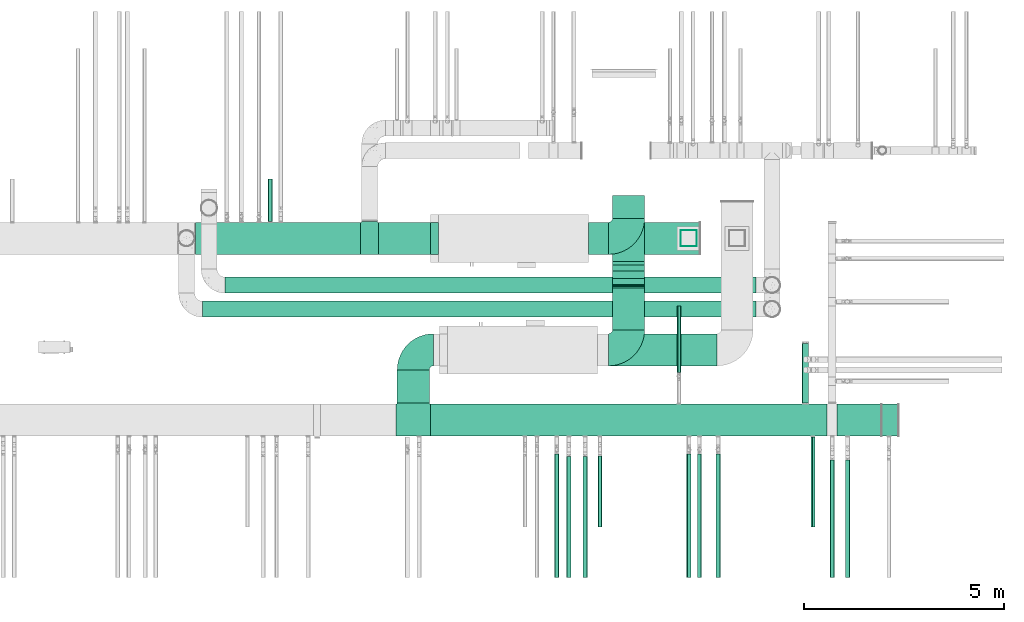
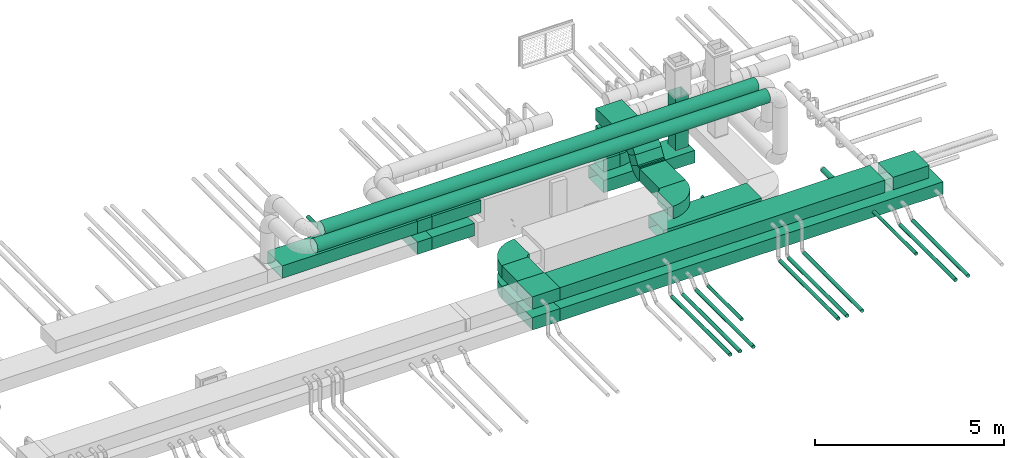
# One storey, part 3 of 91: 31 flow segments, 10 flow fittings.
"""IFC2X3 building model written with IfcOpenShell, lengths in millimetres."""

import ifcopenshell
import ifcopenshell.guid

model = None  # the IFC model being written
_history = None  # IfcOwnerHistory: only IFC2X3 demands one
_inside = {}  # id of a spatial element -> (the spatial element, [elements in it])
_under = {}  # id of a project, library or spatial element -> (it, [spatial elements below it])
_declared = {}  # id of a project -> (the project, [libraries it declares])
_typed = {}  # id of a type object -> (the type object, [elements of that type])
_made_of = {}  # id of a material, layer set ... -> (it, [elements and type objects made of it])


def new_model(schema):
    """Start an empty IFC model of exactly this schema.

    Asked for "IFC4X3", IfcOpenShell would pick the latest addendum, in which some entities
    have other attributes; the version numbers below select the first issue.
    IFC2X3 requires an IfcOwnerHistory on every rooted entity: one is made here for all.
    """
    global model, _history
    if schema == "IFC4X3":
        model = ifcopenshell.file(schema_version=(4, 3, 0, 0))
    else:
        model = ifcopenshell.file(schema=schema)
    _inside.clear()
    _under.clear()
    _declared.clear()
    _typed.clear()
    _made_of.clear()
    _history = None
    if model.schema == "IFC2X3":
        org = make("IfcOrganization", Name="unknown")
        user = make(
            "IfcPersonAndOrganization",
            ThePerson=make("IfcPerson", FamilyName="unknown"),
            TheOrganization=org,
        )
        app = make(
            "IfcApplication",
            ApplicationDeveloper=org,
            Version="unknown",
            ApplicationFullName="unknown",
            ApplicationIdentifier="unknown",
        )
        _history = make(
            "IfcOwnerHistory",
            OwningUser=user,
            OwningApplication=app,
            ChangeAction="ADDED",
            CreationDate=0,
        )
    return model


def make(cls, **values):
    """One entity of the class cls with the attributes given. An attribute that is None is left unset."""
    return model.create_entity(
        cls, **{name: value for name, value in values.items() if value is not None}
    )


def entity(cls, *values):
    """Any entity or typed value of the class cls, its attributes in the order of the schema. None: left unset."""
    e = model.create_entity(cls)
    for i, value in enumerate(values):
        if value is not None:
            e[i] = value
    return e


def rooted(cls, **values):
    """An entity with a GlobalId (a new one), such as an element, a storey or a relation."""
    return make(cls, GlobalId=ifcopenshell.guid.new(), OwnerHistory=_history, **values)


def si_unit(unit_type, name, prefix=None):
    """IfcSIUnit, for example si_unit("LENGTHUNIT", "METRE", prefix="MILLI")."""
    return make("IfcSIUnit", UnitType=unit_type, Prefix=prefix, Name=name)


def converted_unit(unit_type, name, factor, base, dimensions=None, offset=None):
    """IfcConversionBasedUnit, such as the inch: factor (a typed value) times the base unit."""
    return make(
        "IfcConversionBasedUnit"
        if offset is None
        else "IfcConversionBasedUnitWithOffset",
        ConversionOffset=offset,
        Dimensions=None
        if dimensions is None
        else entity("IfcDimensionalExponents", *dimensions),
        UnitType=unit_type,
        Name=name,
        ConversionFactor=make(
            "IfcMeasureWithUnit", ValueComponent=factor, UnitComponent=base
        ),
    )


def derived_unit(unit_type, elements):
    """IfcDerivedUnit: a product of units, each with its exponent."""
    return make(
        "IfcDerivedUnit",
        Elements=[
            make("IfcDerivedUnitElement", Unit=unit, Exponent=power)
            for unit, power in elements
        ],
        UnitType=unit_type,
    )


def assignment(units):
    """IfcUnitAssignment: the units of a project."""
    return None if units is None else make("IfcUnitAssignment", Units=units)


def point(xyz):
    """IfcCartesianPoint."""
    return None if xyz is None else make("IfcCartesianPoint", Coordinates=xyz)


def direction(xyz):
    """IfcDirection."""
    return None if xyz is None else make("IfcDirection", DirectionRatios=xyz)


def frame(location, z_axis=None, x_axis=None):
    """IfcAxis2Placement3D, a coordinate frame: its origin and axes. An axis left out is left unset."""
    return make(
        "IfcAxis2Placement3D",
        Location=point(location),
        Axis=direction(z_axis),
        RefDirection=direction(x_axis),
    )


def frame_2d(location, x_axis=None):
    """IfcAxis2Placement2D, a coordinate frame in the plane: its origin and x axis."""
    return make(
        "IfcAxis2Placement2D", Location=point(location), RefDirection=direction(x_axis)
    )


def origin_with_axes():
    """The frame at (0, 0, 0) with the z axis (0, 0, 1) and the x axis (1, 0, 0) written out."""
    return frame((0.0, 0.0, 0.0), z_axis=(0.0, 0.0, 1.0), x_axis=(1.0, 0.0, 0.0))


def origin_2d_with_axis():
    """The frame at (0, 0) in the plane with the x axis (1, 0) written out."""
    return frame_2d((0.0, 0.0), x_axis=(1.0, 0.0))


def place(relative_to, where):
    """IfcLocalPlacement: puts the frame where relative to a parent placement (None: the world)."""
    return make(
        "IfcLocalPlacement", PlacementRelTo=relative_to, RelativePlacement=where
    )


def context(
    kind, dimensions, precision=None, world=None, true_north=None, identifier=None
):
    """IfcGeometricRepresentationContext, for example the 3D "Model" context."""
    return make(
        "IfcGeometricRepresentationContext",
        ContextIdentifier=identifier,
        ContextType=kind,
        CoordinateSpaceDimension=dimensions,
        Precision=precision,
        WorldCoordinateSystem=world,
        TrueNorth=true_north,
    )


def subcontext(parent, identifier, kind, view, scale=None):
    """IfcGeometricRepresentationSubContext, for example "Body" below "Model"."""
    return make(
        "IfcGeometricRepresentationSubContext",
        ContextIdentifier=identifier,
        ContextType=kind,
        ParentContext=parent,
        TargetScale=scale,
        TargetView=view,
    )


def project(units=None, contexts=None):
    """IfcProject with its units and contexts."""
    return rooted(
        "IfcProject",
        Name="project",
        RepresentationContexts=contexts,
        UnitsInContext=assignment(units),
    )


def spatial(cls, under=None, at=None, **own):
    """A site, building, storey or space (cls), placed at a placement, below another one or the project."""
    s = rooted(cls, ObjectPlacement=at, **own)
    if under is not None:
        _under.setdefault(under.id(), (under, []))[1].append(s)
    return s


def profile(cls, at=None, kind="AREA", **sizes):
    """A parametric profile (cls). Its sizes go by their IFC names, for example OverallWidth=200.0."""
    return make(cls, ProfileType=kind, Position=at, **sizes)


def hollow_rectangle(**sizes):
    """IfcRectangleHollowProfileDef."""
    return profile("IfcRectangleHollowProfileDef", **sizes)


def hollow_circle(**sizes):
    """IfcCircleHollowProfileDef."""
    return profile("IfcCircleHollowProfileDef", **sizes)


def extrude(swept, where, along, depth):
    """IfcExtrudedAreaSolid: the profile swept, set in the frame where, extruded along a direction by depth."""
    return make(
        "IfcExtrudedAreaSolid",
        SweptArea=swept,
        Position=where,
        ExtrudedDirection=direction(along),
        Depth=depth,
    )


def faces_of(points, faces, orient=None, outer=None):
    """IfcFace entities. A face is a list of loops; a loop is a list of indices into points, from 0.

    orient and outer hold one flag for each loop. By default every Orientation is true, the
    first loop of a face is its IfcFaceOuterBound and the others are IfcFaceBound.
    """
    made = []
    for i, loops in enumerate(faces):
        bounds = []
        for j, loop in enumerate(loops):
            is_outer = j == 0 if outer is None else outer[i][j]
            bounds.append(
                make(
                    "IfcFaceOuterBound" if is_outer else "IfcFaceBound",
                    Bound=make("IfcPolyLoop", Polygon=[points[k] for k in loop]),
                    Orientation=True if orient is None else orient[i][j],
                )
            )
        made.append(make("IfcFace", Bounds=bounds))
    return made


def open_shell(faces, orient=None, outer=None):
    """The faces of one IfcOpenShell. surface_model builds it on its shared points."""
    return ("IfcOpenShell", faces, orient, outer)


def surface_model(cls, points, shells):
    """IfcFaceBasedSurfaceModel or IfcShellBasedSurfaceModel (cls): surfaces that need not close."""
    shared = [point(p) for p in points]
    made = [make(c, CfsFaces=faces_of(shared, fs, o, b)) for c, fs, o, b in shells]
    if cls == "IfcFaceBasedSurfaceModel":
        return make(cls, FbsmFaces=made)
    return make(cls, SbsmBoundary=made)


def shape(context_of_items, identifier, shape_type, items):
    """IfcShapeRepresentation: the items that make up one representation, for example the "Body"."""
    return make(
        "IfcShapeRepresentation",
        ContextOfItems=context_of_items,
        RepresentationIdentifier=identifier,
        RepresentationType=shape_type,
        Items=items,
    )


def source(mapping_origin, context_of_items, identifier, shape_type, items):
    """IfcRepresentationMap: a shape defined once, which mapped items show again and again."""
    return make(
        "IfcRepresentationMap",
        MappingOrigin=mapping_origin,
        MappedRepresentation=shape(context_of_items, identifier, shape_type, items),
    )


def transform(
    local_origin,
    x_axis=None,
    y_axis=None,
    z_axis=None,
    scale=None,
    scale2=None,
    scale3=None,
    uniform=True,
):
    """IfcCartesianTransformationOperator3D, or its non-uniform kind. x_axis, y_axis, z_axis: its Axis1, 2, 3."""
    if uniform:
        return make(
            "IfcCartesianTransformationOperator3D",
            Axis1=direction(x_axis),
            Axis2=direction(y_axis),
            LocalOrigin=point(local_origin),
            Scale=scale,
            Axis3=direction(z_axis),
        )
    return make(
        "IfcCartesianTransformationOperator3DnonUniform",
        Axis1=direction(x_axis),
        Axis2=direction(y_axis),
        LocalOrigin=point(local_origin),
        Scale=scale,
        Axis3=direction(z_axis),
        Scale2=scale2,
        Scale3=scale3,
    )


def mapped(mapping_source, mapping_target):
    """IfcMappedItem: shows the shape of a source again, moved by a transform."""
    return make(
        "IfcMappedItem", MappingSource=mapping_source, MappingTarget=mapping_target
    )


def material(Name=None, Category=None):
    """IfcMaterial."""
    return make("IfcMaterial", Name=Name, Category=Category)


def layer(
    of_material, thickness, ventilated=None, Name=None, Category=None, Priority=None
):
    """IfcMaterialLayer: one layer of a wall or slab, of a material (None: an air gap)."""
    return make(
        "IfcMaterialLayer",
        Material=of_material,
        LayerThickness=thickness,
        IsVentilated=ventilated,
        Name=Name,
        Category=Category,
        Priority=Priority,
    )


def layer_set(layers, Name=None):
    """IfcMaterialLayerSet."""
    return make("IfcMaterialLayerSet", MaterialLayers=layers, LayerSetName=Name)


def layer_usage(for_layer_set, set_direction, sense, offset, extent=None):
    """IfcMaterialLayerSetUsage: how a layer set lies in its element."""
    return make(
        "IfcMaterialLayerSetUsage",
        ForLayerSet=for_layer_set,
        LayerSetDirection=set_direction,
        DirectionSense=sense,
        OffsetFromReferenceLine=offset,
        ReferenceExtent=extent,
    )


def made_of(thing, what):
    """Note that an element or type object is made of a material, layer set ...; save() writes the relation."""
    if what is not None:
        _made_of.setdefault(what.id(), (what, []))[1].append(thing)
    return thing


def type_object(cls, material=None, **own):
    """A type object (cls), such as IfcWallType, which elements share."""
    return made_of(rooted(cls, **own), material)


def element(
    cls,
    number,
    at=None,
    inside=None,
    cuts=None,
    type_object=None,
    material=None,
    context=None,
    identifier="Body",
    shape_type=None,
    held_by="IfcProductDefinitionShape",
    body=None,
    shapes=None,
    **own,
):
    """One element of the class cls, such as IfcWall. Its Tag is "e" and its number.

    at: its placement. inside: the storey or other place that contains it. cuts: it is an
    opening in that element (IfcRelVoidsElement). A single representation is given by context,
    identifier, shape_type and body (its items); several are given by shapes. held_by: the class
    of the entity that holds the representations. save() writes the other relations.
    """
    e = rooted(cls, Tag="e%d" % number, ObjectPlacement=at, **own)
    if body is not None:
        shapes = [shape(context, identifier, shape_type, body)]
    if shapes is not None:
        e.Representation = make(held_by, Representations=shapes)
    if inside is not None:
        _inside.setdefault(inside.id(), (inside, []))[1].append(e)
    if cuts is not None:
        rooted(
            "IfcRelVoidsElement", RelatingBuildingElement=cuts, RelatedOpeningElement=e
        )
    if type_object is not None:
        _typed.setdefault(type_object.id(), (type_object, []))[1].append(e)
    return made_of(e, material)


def aggregate(whole, parts):
    """IfcRelAggregates: a whole, such as a stair, and the parts it consists of."""
    return rooted("IfcRelAggregates", RelatingObject=whole, RelatedObjects=parts)


def save(model, path):
    """Write the relations noted so far, then the file.

    IfcRelAggregates (storeys below a building ...), IfcRelContainedInSpatialStructure (elements
    in a storey), IfcRelDefinesByType, IfcRelAssociatesMaterial and IfcRelDeclares: one each for
    every whole, place, type object, material and project.
    """
    for whole, parts in _under.values():
        aggregate(whole, parts)
    for where, things in _inside.values():
        rooted(
            "IfcRelContainedInSpatialStructure",
            RelatedElements=things,
            RelatingStructure=where,
        )
    for kind, things in _typed.values():
        rooted("IfcRelDefinesByType", RelatedObjects=things, RelatingType=kind)
    for what, things in _made_of.values():
        rooted("IfcRelAssociatesMaterial", RelatedObjects=things, RelatingMaterial=what)
    for by, libraries in _declared.values():
        rooted("IfcRelDeclares", RelatingContext=by, RelatedDefinitions=libraries)
    model.write(path)


model = new_model("IFC2X3")

# Units and contexts
model_context = context("Model", 3, precision=1e-05, world=origin_with_axes(), true_north=direction((0.0, 1.0)))
body_context = subcontext(model_context, "Body", "Model", "MODEL_VIEW")
ifc_project = project(units=[si_unit("AREAUNIT", "SQUARE_METRE"), si_unit("VOLUMEUNIT", "CUBIC_METRE", prefix="DECI"), si_unit("TIMEUNIT", "SECOND"), si_unit("THERMODYNAMICTEMPERATUREUNIT", "DEGREE_CELSIUS"), si_unit("PRESSUREUNIT", "PASCAL"), si_unit("MASSUNIT", "GRAM", prefix="KILO"), si_unit("LENGTHUNIT", "METRE", prefix="MILLI"), si_unit("POWERUNIT", "WATT"), si_unit("ELECTRICCURRENTUNIT", "AMPERE"), si_unit("ELECTRICVOLTAGEUNIT", "VOLT"), derived_unit("VOLUMETRICFLOWRATEUNIT", [(si_unit("VOLUMEUNIT", "CUBIC_METRE", prefix="DECI"), 1), (si_unit("TIMEUNIT", "SECOND"), -1)]), derived_unit("LINEARVELOCITYUNIT", [(si_unit("LENGTHUNIT", "METRE"), 1), (si_unit("TIMEUNIT", "SECOND"), -1)]), derived_unit("MASSDENSITYUNIT", [(si_unit("MASSUNIT", "GRAM", prefix="KILO"), 1), (si_unit("VOLUMEUNIT", "CUBIC_METRE"), -1)]), converted_unit("PLANEANGLEUNIT", "DEGREE", entity("IfcRatioMeasure", 0.01745), si_unit("PLANEANGLEUNIT", "RADIAN"), dimensions=[0, 0, 0, 0, 0, 0, 0])], contexts=[model_context])

# Site, building, storey
site_placement = place(None, origin_with_axes())
site = spatial("IfcSite", under=ifc_project, at=site_placement, CompositionType="ELEMENT")
building_placement = place(site_placement, origin_with_axes())
building = spatial("IfcBuilding", under=site, at=building_placement, Name="mc-building", CompositionType="ELEMENT")
storey_placement = place(building_placement, frame((0.0, 0.0, 8700.0), z_axis=(0.0, 0.0, 1.0), x_axis=(1.0, 0.0, 0.0)))
storey = spatial("IfcBuildingStorey", under=building, at=storey_placement, CompositionType="ELEMENT", Elevation=8700.0)

# Flow segments
ifc_material_1 = material(Name="FZ1")
ifc_layer_1 = layer(ifc_material_1, 0.0)
ifc_layer_set_1 = layer_set([ifc_layer_1], Name="FZ1")
ifc_layer_usage_1 = layer_usage(ifc_layer_set_1, "AXIS1", "POSITIVE", 0.0)
duct_segment_type_1 = type_object("IfcDuctSegmentType", PredefinedType="RIGIDSEGMENT")
shared_shape_1 = source(origin_with_axes(), body_context, "Body", "SweptSolid", [
    extrude(hollow_circle(Radius=50.0, WallThickness=2.0, at=origin_2d_with_axis()), frame((0.0, 0.0, 0.0), z_axis=(1.0, 0.0, 0.0), x_axis=(0.0, 1.0, 0.0)), (0.0, 0.0, 1.0), 2257.3),
])
flow_segment_1_placement = place(storey_placement, frame((32887.39425, 673.88887, 668.0), z_axis=(0.0, 0.0, 1.0), x_axis=(0.0, 1.0, 0.0)))
element("IfcFlowSegment", 1, at=flow_segment_1_placement, inside=storey, type_object=duct_segment_type_1, material=ifc_layer_usage_1, context=body_context, shape_type="MappedRepresentation", body=[
    mapped(shared_shape_1, transform((0.0, 0.0, 0.0), scale=1.0)),
])
ifc_material_2 = material(Name="1")
ifc_layer_2 = layer(ifc_material_2, 0.0)
ifc_layer_set_2 = layer_set([ifc_layer_2], Name="1")
ifc_layer_usage_2 = layer_usage(ifc_layer_set_2, "AXIS1", "POSITIVE", 0.0)
duct_segment_type_2 = type_object("IfcDuctSegmentType", PredefinedType="RIGIDSEGMENT")
shared_shape_2 = source(origin_with_axes(), body_context, "Body", "SweptSolid", [
    extrude(hollow_rectangle(XDim=800.0, YDim=400.0, WallThickness=2.0, at=origin_2d_with_axis()), frame((0.0, 0.0, 0.0), z_axis=(1.0, 0.0, 0.0), x_axis=(0.0, 1.0, 0.0)), (0.0, 0.0, 1.0), 574.5),
])
flow_segment_2_placement = place(storey_placement, frame((28279.85899, 8390.34565, 1344.0), z_axis=(0.0, 0.0, 1.0), x_axis=(0.0, 1.0, 0.0)))
element("IfcFlowSegment", 2, at=flow_segment_2_placement, inside=storey, type_object=duct_segment_type_2, material=ifc_layer_usage_2, context=body_context, shape_type="MappedRepresentation", body=[
    mapped(shared_shape_2, transform((0.0, 0.0, 0.0), scale=1.0)),
])
shared_shape_3 = source(origin_with_axes(), body_context, "Body", "SweptSolid", [
    extrude(hollow_rectangle(XDim=800.0, YDim=400.0, WallThickness=2.0, at=origin_2d_with_axis()), frame((0.0, 0.0, 0.0), z_axis=(1.0, 0.0, 0.0), x_axis=(0.0, 1.0, 0.0)), (0.0, 0.0, 1.0), 1650.4),
])
flow_segment_3_placement = place(storey_placement, frame((28279.85899, 7314.41021, 1900.0), z_axis=(0.0, 0.0, 1.0), x_axis=(0.0, 1.0, 0.0)))
element("IfcFlowSegment", 3, at=flow_segment_3_placement, inside=storey, type_object=duct_segment_type_2, material=ifc_layer_usage_2, context=body_context, shape_type="MappedRepresentation", body=[
    mapped(shared_shape_3, transform((0.0, 0.0, 0.0), scale=1.0)),
])
shared_shape_4 = source(origin_with_axes(), body_context, "Body", "SweptSolid", [
    extrude(hollow_rectangle(XDim=800.0, YDim=400.0, WallThickness=2.0, at=origin_2d_with_axis()), frame((0.0, 0.0, 0.0), z_axis=(1.0, 0.0, 0.0), x_axis=(0.0, 1.0, 0.0)), (0.0, 0.0, 1.0), 828.3),
])
for number, where, z_axis, x_axis in (
    (4, (22900.0, 4604.45799, 1344.0), (0.0, 0.0, 1.0), (0.0, -1.0, 0.0)),
    (5, (22900.0, 4604.45799, 668.0), (0.0, 0.0, 1.0), (0.0, -1.0, 0.0)),
):
    element("IfcFlowSegment", number, at=place(storey_placement, frame(where, z_axis=z_axis, x_axis=x_axis)), inside=storey, type_object=duct_segment_type_2, material=ifc_layer_usage_2, context=body_context, shape_type="MappedRepresentation", body=[
        mapped(shared_shape_4, transform((0.0, 0.0, 0.0), scale=1.0)),
    ])

# Flow fittings
duct_fitting_type_1 = type_object("IfcDuctFittingType", Name="RR1", PredefinedType="JUNCTION")
shared_shape_5 = source(origin_with_axes(), body_context, "Body", "SurfaceModel", [
    surface_model("IfcShellBasedSurfaceModel", [(-425.0, 400.0, 200.0), (-425.0, 400.0, -200.0), (-425.0, -400.0, -200.0), (-425.0, -400.0, 200.0), (425.0, -400.0, -200.0), (425.0, 400.0, -200.0), (425.0, 400.0, 200.0), (425.0, -400.0, 200.0), (-400.0, -425.0, -200.0), (400.0, -425.0, -200.0), (400.0, -425.0, 200.0), (-400.0, -425.0, 200.0), (-400.0, -400.0, -200.0), (400.0, -400.0, -200.0), (-400.0, -400.0, 200.0), (400.0, -400.0, 200.0)], [open_shell([[[0, 1, 2]], [[2, 3, 0]], [[4, 5, 6]], [[6, 7, 4]], [[8, 9, 10]], [[10, 11, 8]], [[1, 0, 5]], [[6, 5, 0]], [[1, 12, 2]], [[12, 1, 5]], [[12, 13, 8]], [[13, 5, 4]], [[5, 13, 12]], [[13, 9, 8]], [[3, 2, 12]], [[12, 14, 3]], [[15, 13, 7]], [[4, 7, 13]], [[0, 14, 6]], [[14, 0, 3]], [[11, 15, 14]], [[15, 6, 14]], [[6, 15, 7]], [[10, 15, 11]], [[13, 15, 10]], [[10, 9, 13]], [[14, 12, 11]], [[8, 11, 12]]])]),
])
for number, where, z_axis, x_axis, name in (
    (6, (22900.0, 3351.20513, 1344.0), (0.0, 0.0, 1.0), (-1.0, 0.0, 0.0), "RR1"),
    (7, (22900.0, 3351.20513, 668.0), (0.0, 0.0, 1.0), (-1.0, 0.0, 0.0), "RR1"),
):
    element("IfcFlowFitting", number, at=place(storey_placement, frame(where, z_axis=z_axis, x_axis=x_axis)), inside=storey, type_object=duct_fitting_type_1, Name=name, context=body_context, shape_type="MappedRepresentation", body=[
        mapped(shared_shape_5, transform((0.0, 0.0, 0.0), scale=1.0)),
    ])

# Flow segments
shared_shape_6 = source(origin_with_axes(), body_context, "Body", "SweptSolid", [
    extrude(hollow_rectangle(XDim=800.0, YDim=400.0, WallThickness=2.0, at=origin_2d_with_axis()), frame((0.0, 0.0, 0.0), z_axis=(1.0, 0.0, 0.0), x_axis=(0.0, 1.0, 0.0)), (0.0, 0.0, 1.0), 11698.8),
])
flow_segment_4_placement = place(storey_placement, frame((23325.0, 3351.20513, 668.0), z_axis=(0.0, 0.0, 1.0), x_axis=(1.0, 0.0, 0.0)))
element("IfcFlowSegment", 8, at=flow_segment_4_placement, inside=storey, type_object=duct_segment_type_2, material=ifc_layer_usage_2, context=body_context, shape_type="MappedRepresentation", body=[
    mapped(shared_shape_6, transform((0.0, 0.0, 0.0), scale=1.0)),
])
shared_shape_7 = source(origin_with_axes(), body_context, "Body", "SweptSolid", [
    extrude(hollow_circle(Radius=55.0, WallThickness=2.0, at=origin_2d_with_axis()), frame((0.0, 0.0, 0.0), z_axis=(1.0, 0.0, 0.0), x_axis=(0.0, 1.0, 0.0)), (0.0, 0.0, 1.0), 3080.0),
])
for number, where, z_axis, x_axis in (
    (9, (30053.28275, -577.64676, 415.0), (0.0, 0.0, 1.0), (0.0, 1.0, 0.0)),
    (10, (30518.54047, -577.64676, 415.0), (0.0, 0.0, 1.0), (0.0, 1.0, 0.0)),
    (11, (26486.51753, -577.64676, 415.0), (0.0, 0.0, 1.0), (0.0, 1.0, 0.0)),
    (12, (29788.00747, -577.64676, 415.0), (0.0, 0.0, 1.0), (0.0, 1.0, 0.0)),
):
    element("IfcFlowSegment", number, at=place(storey_placement, frame(where, z_axis=z_axis, x_axis=x_axis)), inside=storey, type_object=duct_segment_type_1, material=ifc_layer_usage_1, context=body_context, shape_type="MappedRepresentation", body=[
        mapped(shared_shape_7, transform((0.0, 0.0, 0.0), scale=1.0)),
    ])
shared_shape_8 = source(origin_with_axes(), body_context, "Body", "SweptSolid", [
    extrude(hollow_circle(Radius=55.0, WallThickness=2.0, at=origin_2d_with_axis()), frame((0.0, 0.0, 0.0), z_axis=(1.0, 0.0, 0.0), x_axis=(0.0, 1.0, 0.0)), (0.0, 0.0, 1.0), 3019.6),
])
for number, where, z_axis, x_axis in (
    (13, (26787.42189, -577.64676, 415.0), (0.0, 0.0, 1.0), (0.0, 1.0, 0.0)),
    (14, (27194.49649, -577.64676, 415.0), (0.0, 0.0, 1.0), (0.0, 1.0, 0.0)),
):
    element("IfcFlowSegment", number, at=place(storey_placement, frame(where, z_axis=z_axis, x_axis=x_axis)), inside=storey, type_object=duct_segment_type_1, material=ifc_layer_usage_1, context=body_context, shape_type="MappedRepresentation", body=[
        mapped(shared_shape_8, transform((0.0, 0.0, 0.0), scale=1.0)),
    ])
shared_shape_9 = source(origin_with_axes(), body_context, "Body", "SweptSolid", [
    extrude(hollow_circle(Radius=55.0, WallThickness=2.0, at=origin_2d_with_axis()), frame((0.0, 0.0, 0.0), z_axis=(1.0, 0.0, 0.0), x_axis=(0.0, 1.0, 0.0)), (0.0, 0.0, 1.0), 2931.7),
])
for number, where, z_axis, x_axis in (
    (15, (33752.94253, -577.64676, 415.0), (0.0, 0.0, 1.0), (0.0, 1.0, 0.0)),
    (16, (33368.54901, -577.64676, 415.0), (0.0, 0.0, 1.0), (0.0, 1.0, 0.0)),
):
    element("IfcFlowSegment", number, at=place(storey_placement, frame(where, z_axis=z_axis, x_axis=x_axis)), inside=storey, type_object=duct_segment_type_1, material=ifc_layer_usage_1, context=body_context, shape_type="MappedRepresentation", body=[
        mapped(shared_shape_9, transform((0.0, 0.0, 0.0), scale=1.0)),
    ])
shared_shape_10 = source(origin_with_axes(), body_context, "Body", "SweptSolid", [
    extrude(hollow_circle(Radius=50.0, WallThickness=2.0, at=origin_2d_with_axis()), frame((0.0, 0.0, 0.0), z_axis=(1.0, 0.0, 0.0), x_axis=(0.0, 1.0, 0.0)), (0.0, 0.0, 1.0), 1777.2),
])
flow_segment_5_placement = place(storey_placement, frame((27561.56962, 673.88887, 415.0), z_axis=(0.0, 0.0, 1.0), x_axis=(0.0, 1.0, 0.0)))
element("IfcFlowSegment", 17, at=flow_segment_5_placement, inside=storey, type_object=duct_segment_type_1, material=ifc_layer_usage_1, context=body_context, shape_type="MappedRepresentation", body=[
    mapped(shared_shape_10, transform((0.0, 0.0, 0.0), scale=1.0)),
])
shared_shape_11 = source(origin_with_axes(), body_context, "Body", "SweptSolid", [
    extrude(hollow_circle(Radius=55.0, WallThickness=2.0, at=origin_2d_with_axis()), frame((0.0, 0.0, 0.0), z_axis=(1.0, 0.0, 0.0), x_axis=(0.0, 1.0, 0.0)), (0.0, 0.0, 1.0), 1057.3),
])
flow_segment_6_placement = place(storey_placement, frame((19326.27346, 9367.62755, 1344.0), z_axis=(0.0, 0.0, 1.0), x_axis=(0.0, -1.0, 0.0)))
element("IfcFlowSegment", 18, at=flow_segment_6_placement, inside=storey, type_object=duct_segment_type_1, material=ifc_layer_usage_1, context=body_context, shape_type="MappedRepresentation", body=[
    mapped(shared_shape_11, transform((0.0, 0.0, 0.0), scale=1.0)),
])
duct_segment_type_3 = type_object("IfcDuctSegmentType", PredefinedType="RIGIDSEGMENT")
shared_shape_12 = source(origin_with_axes(), body_context, "Body", "SweptSolid", [
    extrude(hollow_rectangle(XDim=800.0, YDim=400.0, WallThickness=2.0, at=origin_2d_with_axis()), frame((0.0, 0.0, 0.0), z_axis=(1.0, 0.0, 0.0), x_axis=(0.0, 1.0, 0.0)), (0.0, 0.0, 1.0), 9914.8),
])
flow_segment_7_placement = place(storey_placement, frame((23325.0, 3351.20513, 1344.0), z_axis=(0.0, 0.0, 1.0), x_axis=(1.0, 0.0, 0.0)))
element("IfcFlowSegment", 19, at=flow_segment_7_placement, inside=storey, type_object=duct_segment_type_3, material=ifc_layer_usage_2, context=body_context, shape_type="MappedRepresentation", body=[
    mapped(shared_shape_12, transform((0.0, 0.0, 0.0), scale=1.0)),
])
shared_shape_13 = source(origin_with_axes(), body_context, "Body", "SweptSolid", [
    extrude(hollow_rectangle(XDim=800.0, YDim=400.0, WallThickness=2.0, at=origin_2d_with_axis()), frame((0.0, 0.0, 0.0), z_axis=(1.0, 0.0, 0.0), x_axis=(0.0, 1.0, 0.0)), (0.0, 0.0, 1.0), 1290.7),
])
flow_segment_8_placement = place(storey_placement, frame((22035.56538, 7890.34565, 668.0), z_axis=(0.0, 0.0, 1.0), x_axis=(1.0, 0.0, 0.0)))
element("IfcFlowSegment", 20, at=flow_segment_8_placement, inside=storey, type_object=duct_segment_type_2, material=ifc_layer_usage_2, context=body_context, shape_type="MappedRepresentation", body=[
    mapped(shared_shape_13, transform((0.0, 0.0, 0.0), scale=1.0)),
])

# Flow fittings
shared_shape_14 = source(origin_with_axes(), body_context, "Body", "SurfaceModel", [
    surface_model("IfcShellBasedSurfaceModel", [(-225.0, 400.0, 200.0), (-225.0, 400.0, -200.0), (-225.0, -400.0, -200.0), (-225.0, -400.0, 200.0), (225.0, -400.0, -200.0), (225.0, 400.0, -200.0), (225.0, -400.0, 200.0), (225.0, 400.0, 200.0), (-200.0, -425.0, -200.0), (200.0, -425.0, -200.0), (-200.0, -425.0, 200.0), (200.0, -425.0, 200.0), (-200.0, -400.0, -200.0), (200.0, -400.0, -200.0), (-200.0, -400.0, 200.0), (200.0, -400.0, 200.0)], [open_shell([[[0, 1, 2]], [[2, 3, 0]], [[4, 5, 6]], [[7, 6, 5]], [[8, 9, 10]], [[11, 10, 9]], [[1, 0, 7]], [[7, 5, 1]], [[1, 12, 2]], [[12, 1, 5]], [[12, 13, 8]], [[13, 5, 4]], [[5, 13, 12]], [[13, 9, 8]], [[3, 2, 12]], [[12, 14, 3]], [[15, 13, 4]], [[4, 6, 15]], [[0, 14, 7]], [[14, 0, 3]], [[10, 15, 14]], [[15, 7, 14]], [[7, 15, 6]], [[11, 15, 10]], [[13, 15, 11]], [[11, 9, 13]], [[14, 12, 10]], [[8, 10, 12]]])]),
])
for number, where, z_axis, x_axis, name in (
    (21, (21810.56538, 7890.34565, 668.0), (0.0, 0.0, 1.0), (-1.0, 0.0, 0.0), "RR1"),
    (22, (21810.56538, 7890.34565, 1344.0), (0.0, 0.0, 1.0), (-1.0, 0.0, 0.0), "RR1"),
):
    element("IfcFlowFitting", number, at=place(storey_placement, frame(where, z_axis=z_axis, x_axis=x_axis)), inside=storey, type_object=duct_fitting_type_1, Name=name, context=body_context, shape_type="MappedRepresentation", body=[
        mapped(shared_shape_14, transform((0.0, 0.0, 0.0), scale=1.0)),
    ])
duct_fitting_type_2 = type_object("IfcDuctFittingType", Name="R1", PredefinedType="BEND")
shared_shape_15 = source(origin_with_axes(), body_context, "Body", "SurfaceModel", [
    surface_model("IfcShellBasedSurfaceModel", [(-500.0, 400.0, 200.0), (-500.0, 400.0, -200.0), (-500.0, -400.0, -200.0), (-500.0, -400.0, 200.0), (400.0, 500.0, -200.0), (-400.0, 500.0, -200.0), (-400.0, 500.0, 200.0), (400.0, 500.0, 200.0), (-469.09829, 404.89436, 200.0), (-441.22147, 419.09829, -200.0), (-469.09829, 404.89436, -200.0), (-441.22147, 419.09829, 200.0), (-419.09829, 441.22147, -200.0), (-404.89436, 469.09829, -200.0), (-419.09829, 441.22147, 200.0), (-404.89436, 469.09829, 200.0), (310.87198, 109.50464, -200.0), (349.49498, 202.74885, -200.0), (-109.50464, -310.87198, -200.0), (136.3961, -136.3961, -200.0), (394.34097, 399.23195, -200.0), (377.43514, 299.73116, -200.0), (-399.23195, -394.34097, -200.0), (-202.74885, -349.49498, -200.0), (-299.73116, -377.43514, -200.0), (-21.17113, -262.05177, -200.0), (262.05177, 21.17113, -200.0), (203.64833, -61.14082, -200.0), (61.14082, -203.64833, -200.0), (-399.23195, -394.34097, 200.0), (-299.73116, -377.43514, 200.0), (-21.17113, -262.05177, 200.0), (-109.50464, -310.87198, 200.0), (61.14082, -203.64833, 200.0), (-202.74885, -349.49498, 200.0), (136.3961, -136.3961, 200.0), (203.64833, -61.14082, 200.0), (262.05177, 21.17113, 200.0), (377.43514, 299.73116, 200.0), (349.49498, 202.74885, 200.0), (310.87198, 109.50464, 200.0), (394.34097, 399.23195, 200.0)], [open_shell([[[0, 1, 2]], [[2, 3, 0]], [[4, 5, 6]], [[6, 7, 4]], [[8, 9, 10]], [[8, 10, 1]], [[1, 0, 8]], [[9, 8, 11]], [[11, 12, 9]], [[13, 12, 14]], [[5, 13, 15]], [[14, 15, 13]], [[6, 5, 15]], [[11, 14, 12]], [[16, 13, 17]], [[10, 9, 18]], [[9, 12, 19]], [[12, 13, 16]], [[20, 5, 4]], [[5, 20, 13]], [[20, 21, 13]], [[21, 17, 13]], [[22, 1, 10]], [[23, 10, 18]], [[10, 23, 24]], [[22, 10, 24]], [[25, 18, 9]], [[16, 26, 12]], [[12, 26, 27]], [[9, 19, 28]], [[27, 19, 12]], [[25, 9, 28]], [[22, 2, 1]], [[29, 2, 22]], [[30, 22, 24]], [[31, 25, 28]], [[32, 18, 25]], [[28, 19, 33]], [[23, 34, 30]], [[29, 22, 30]], [[2, 29, 3]], [[23, 32, 34]], [[23, 18, 32]], [[32, 25, 31]], [[28, 33, 31]], [[23, 30, 24]], [[19, 35, 33]], [[36, 27, 26]], [[16, 37, 26]], [[21, 20, 38]], [[39, 17, 21]], [[40, 16, 17]], [[41, 20, 4]], [[35, 27, 36]], [[36, 26, 37]], [[40, 37, 16]], [[17, 39, 40]], [[21, 38, 39]], [[41, 38, 20]], [[4, 7, 41]], [[27, 35, 19]], [[39, 15, 40]], [[32, 11, 8]], [[35, 14, 11]], [[40, 15, 14]], [[7, 6, 41]], [[15, 41, 6]], [[15, 38, 41]], [[15, 39, 38]], [[8, 0, 29]], [[32, 8, 34]], [[30, 34, 8]], [[30, 8, 29]], [[11, 32, 31]], [[14, 37, 40]], [[36, 37, 14]], [[33, 35, 11]], [[14, 35, 36]], [[33, 11, 31]], [[0, 3, 29]]])]),
])
for number, where, z_axis, x_axis, name in (
    (23, (22900.0, 5104.45799, 1344.0), (0.0, 0.0, 1.0), (-1.0, 0.0, 0.0), "R1"),
    (24, (22900.0, 5104.45799, 668.0), (0.0, 0.0, 1.0), (-1.0, 0.0, 0.0), "R1"),
    (25, (28279.85899, 5104.45799, 1344.0), (0.0, 0.0, 1.0), (1.0, 0.0, 0.0), "R1"),
    (26, (28279.85899, 7890.34565, 1344.0), (0.0, 0.0, 1.0), (1.0, 0.0, 0.0), "R1"),
):
    element("IfcFlowFitting", number, at=place(storey_placement, frame(where, z_axis=z_axis, x_axis=x_axis)), inside=storey, type_object=duct_fitting_type_2, Name=name, context=body_context, shape_type="MappedRepresentation", body=[
        mapped(shared_shape_15, transform((0.0, 0.0, 0.0), scale=1.0)),
    ])

# Flow segments
shared_shape_16 = source(origin_with_axes(), body_context, "Body", "SweptSolid", [
    extrude(hollow_rectangle(XDim=800.0, YDim=400.0, WallThickness=2.0, at=origin_2d_with_axis()), frame((0.0, 0.0, 0.0), z_axis=(1.0, 0.0, 0.0), x_axis=(0.0, 1.0, 0.0)), (0.0, 0.0, 1.0), 2990.3),
])
flow_segment_9_placement = place(storey_placement, frame((27500.0, 5104.45799, 668.0), z_axis=(0.0, 0.0, 1.0), x_axis=(1.0, 0.0, 0.0)))
element("IfcFlowSegment", 27, at=flow_segment_9_placement, inside=storey, type_object=duct_segment_type_2, material=ifc_layer_usage_2, context=body_context, shape_type="MappedRepresentation", body=[
    mapped(shared_shape_16, transform((0.0, 0.0, 0.0), scale=1.0)),
])
shared_shape_17 = source(origin_with_axes(), body_context, "Body", "SweptSolid", [
    extrude(hollow_rectangle(XDim=800.0, YDim=400.0, WallThickness=2.0, at=origin_2d_with_axis()), frame((0.0, 0.0, 0.0), z_axis=(1.0, 0.0, 0.0), x_axis=(0.0, 1.0, 0.0)), (0.0, 0.0, 1.0), 2782.4),
])
flow_segment_10_placement = place(storey_placement, frame((27276.26664, 7890.34565, 668.0), z_axis=(0.0, 0.0, 1.0), x_axis=(1.0, 0.0, 0.0)))
element("IfcFlowSegment", 28, at=flow_segment_10_placement, inside=storey, type_object=duct_segment_type_2, material=ifc_layer_usage_2, context=body_context, shape_type="MappedRepresentation", body=[
    mapped(shared_shape_17, transform((0.0, 0.0, 0.0), scale=1.0)),
])
shared_shape_18 = source(origin_with_axes(), body_context, "Body", "SweptSolid", [
    extrude(hollow_rectangle(XDim=800.0, YDim=400.0, WallThickness=2.0, at=origin_2d_with_axis()), frame((0.0, 0.0, 0.0), z_axis=(1.0, 0.0, 0.0), x_axis=(0.0, 1.0, 0.0)), (0.0, 0.0, 1.0), 503.6),
])
flow_segment_11_placement = place(storey_placement, frame((27779.85899, 7890.34565, 1344.0), z_axis=(0.0, 0.0, 1.0), x_axis=(-1.0, 0.0, 0.0)))
element("IfcFlowSegment", 29, at=flow_segment_11_placement, inside=storey, type_object=duct_segment_type_2, material=ifc_layer_usage_2, context=body_context, shape_type="MappedRepresentation", body=[
    mapped(shared_shape_18, transform((0.0, 0.0, 0.0), scale=1.0)),
])
shared_shape_19 = source(origin_with_axes(), body_context, "Body", "SweptSolid", [
    extrude(hollow_rectangle(XDim=800.0, YDim=400.0, WallThickness=2.0, at=origin_2d_with_axis()), frame((0.0, 0.0, 0.0), z_axis=(1.0, 0.0, 0.0), x_axis=(0.0, 1.0, 0.0)), (0.0, 0.0, 1.0), 1042.5),
])
flow_segment_12_placement = place(storey_placement, frame((28279.85899, 5604.45799, 1344.0), z_axis=(0.0, 0.0, 1.0), x_axis=(0.0, 1.0, 0.0)))
element("IfcFlowSegment", 30, at=flow_segment_12_placement, inside=storey, type_object=duct_segment_type_2, material=ifc_layer_usage_2, context=body_context, shape_type="MappedRepresentation", body=[
    mapped(shared_shape_19, transform((0.0, 0.0, 0.0), scale=1.0)),
])
shared_shape_20 = source(origin_with_axes(), body_context, "Body", "SweptSolid", [
    extrude(hollow_rectangle(XDim=800.0, YDim=400.0, WallThickness=2.0, at=origin_2d_with_axis()), frame((0.0, 0.0, 0.0), z_axis=(1.0, 0.0, 0.0), x_axis=(0.0, 1.0, 0.0)), (0.0, 0.0, 1.0), 295.5),
])
flow_segment_13_placement = place(storey_placement, frame((28279.85899, 6906.85866, 1494.1), z_axis=(0.0, -0.866025, 0.5), x_axis=(0.0, 0.5, 0.866025)))
element("IfcFlowSegment", 31, at=flow_segment_13_placement, inside=storey, type_object=duct_segment_type_2, material=ifc_layer_usage_2, context=body_context, shape_type="MappedRepresentation", body=[
    mapped(shared_shape_20, transform((0.0, 0.0, 0.0), scale=1.0)),
])

# Flow fittings
shared_shape_21 = source(origin_with_axes(), body_context, "Body", "SurfaceModel", [
    surface_model("IfcShellBasedSurfaceModel", [(-173.20509, 200.0, 400.0), (-173.20509, 200.0, -400.0), (-173.20509, -200.0, -400.0), (-173.20509, -200.0, 400.0), (259.80762, 50.0, -400.0), (-86.60254, 250.0, -400.0), (-86.60254, 250.0, 400.0), (259.80762, 50.0, 400.0), (-139.00307, 206.03074, 400.0), (-139.00307, 206.03074, -400.0), (-108.92632, 223.39556, -400.0), (-108.92632, 223.39556, 400.0), (108.45494, -113.11939, -400.0), (166.88129, -66.52594, -400.0), (217.71066, -11.7449, -400.0), (-98.68395, -194.4154, -400.0), (-25.82749, -177.7864, -400.0), (43.73679, -150.48444, -400.0), (-25.82749, -177.7864, 400.0), (-98.68395, -194.4154, 400.0), (43.73679, -150.48444, 400.0), (108.45494, -113.11939, 400.0), (166.88129, -66.52594, 400.0), (217.71066, -11.7449, 400.0)], [open_shell([[[0, 1, 2]], [[2, 3, 0]], [[4, 5, 6]], [[6, 7, 4]], [[8, 9, 1]], [[1, 0, 8]], [[8, 10, 9]], [[11, 5, 10]], [[5, 11, 6]], [[8, 11, 10]], [[9, 10, 12]], [[13, 10, 14]], [[4, 14, 5]], [[10, 5, 14]], [[15, 1, 9]], [[16, 15, 9]], [[17, 16, 9]], [[10, 13, 12]], [[12, 17, 9]], [[1, 15, 2]], [[2, 15, 3]], [[15, 16, 18]], [[18, 16, 17]], [[19, 3, 15]], [[18, 19, 15]], [[17, 20, 18]], [[17, 12, 20]], [[21, 12, 13]], [[22, 13, 14]], [[23, 14, 4]], [[21, 13, 22]], [[22, 14, 23]], [[4, 7, 23]], [[12, 21, 20]], [[21, 11, 8]], [[23, 11, 22]], [[6, 23, 7]], [[23, 6, 11]], [[8, 0, 19]], [[8, 19, 18]], [[8, 18, 20]], [[21, 22, 11]], [[8, 20, 21]], [[3, 19, 0]]])]),
])
for number, where, z_axis, x_axis, name in (
    (32, (28279.85899, 6820.25612, 1344.1), (-1.0, 0.0, 0.0), (0.0, -0.5, -0.866025), "R1"),
    (33, (28279.85899, 7141.20513, 1900.0), (1.0, 0.0, 0.0), (0.0, -1.0, 0.0), "R1"),
):
    element("IfcFlowFitting", number, at=place(storey_placement, frame(where, z_axis=z_axis, x_axis=x_axis)), inside=storey, type_object=duct_fitting_type_2, Name=name, context=body_context, shape_type="MappedRepresentation", body=[
        mapped(shared_shape_21, transform((0.0, 0.0, 0.0), scale=1.0)),
    ])

# Flow segments
shared_shape_22 = source(origin_with_axes(), body_context, "Body", "SweptSolid", [
    extrude(hollow_rectangle(XDim=800.0, YDim=400.0, WallThickness=2.0, at=origin_2d_with_axis()), frame((0.0, 0.0, 0.0), z_axis=(1.0, 0.0, 0.0), x_axis=(0.0, 1.0, 0.0)), (0.0, 0.0, 1.0), 1103.4),
])
flow_segment_14_placement = place(storey_placement, frame((33489.76981, 3351.20513, 1344.0), z_axis=(0.0, 0.0, 1.0), x_axis=(1.0, 0.0, 0.0)))
element("IfcFlowSegment", 34, at=flow_segment_14_placement, inside=storey, type_object=duct_segment_type_3, material=ifc_layer_usage_2, context=body_context, shape_type="MappedRepresentation", body=[
    mapped(shared_shape_22, transform((0.0, 0.0, 0.0), scale=1.0)),
])
shared_shape_23 = source(origin_with_axes(), body_context, "Body", "SweptSolid", [
    extrude(hollow_rectangle(XDim=800.0, YDim=400.0, WallThickness=2.0, at=origin_2d_with_axis()), frame((0.0, 0.0, 0.0), z_axis=(1.0, 0.0, 0.0), x_axis=(0.0, 1.0, 0.0)), (0.0, 0.0, 1.0), 1490.7),
])
flow_segment_15_placement = place(storey_placement, frame((22035.56538, 7890.34565, 1344.0), z_axis=(0.0, 0.0, 1.0), x_axis=(1.0, 0.0, 0.0)))
element("IfcFlowSegment", 35, at=flow_segment_15_placement, inside=storey, type_object=duct_segment_type_2, material=ifc_layer_usage_2, context=body_context, shape_type="MappedRepresentation", body=[
    mapped(shared_shape_23, transform((0.0, 0.0, 0.0), scale=1.0)),
])
duct_segment_type_4 = type_object("IfcDuctSegmentType", Name="Safe", PredefinedType="RIGIDSEGMENT")
shared_shape_24 = source(origin_with_axes(), body_context, "Body", "SweptSolid", [
    extrude(hollow_circle(Radius=200.0, WallThickness=2.0, at=origin_2d_with_axis()), frame((0.0, 0.0, 0.0), z_axis=(1.0, 0.0, 0.0), x_axis=(0.0, 1.0, 0.0)), (0.0, 0.0, 1.0), 13266.6),
])
flow_segment_16_placement = place(storey_placement, frame((31466.56389, 6720.97227, 2971.08071), z_axis=(0.0, 0.0, 1.0), x_axis=(-1.0, 0.0, 0.0)))
element("IfcFlowSegment", 36, at=flow_segment_16_placement, inside=storey, type_object=duct_segment_type_4, material=ifc_layer_usage_1, Name="Safe", context=body_context, shape_type="MappedRepresentation", body=[
    mapped(shared_shape_24, transform((0.0, 0.0, 0.0), scale=1.0)),
])
shared_shape_25 = source(origin_with_axes(), body_context, "Body", "SweptSolid", [
    extrude(hollow_circle(Radius=200.0, WallThickness=2.0, at=origin_2d_with_axis()), frame((0.0, 0.0, 0.0), z_axis=(1.0, 0.0, 0.0), x_axis=(0.0, 1.0, 0.0)), (0.0, 0.0, 1.0), 13828.5),
])
flow_segment_17_placement = place(storey_placement, frame((31466.56389, 6120.95522, 2971.08071), z_axis=(0.0, 0.0, 1.0), x_axis=(-1.0, 0.0, 0.0)))
element("IfcFlowSegment", 37, at=flow_segment_17_placement, inside=storey, type_object=duct_segment_type_4, material=ifc_layer_usage_1, Name="Safe", context=body_context, shape_type="MappedRepresentation", body=[
    mapped(shared_shape_25, transform((0.0, 0.0, 0.0), scale=1.0)),
])
shared_shape_26 = source(origin_with_axes(), body_context, "Body", "SweptSolid", [
    extrude(hollow_rectangle(XDim=800.0, YDim=400.0, WallThickness=2.0, at=origin_2d_with_axis()), frame((0.0, 0.0, 0.0), z_axis=(1.0, 0.0, 0.0), x_axis=(0.0, 1.0, 0.0)), (0.0, 0.0, 1.0), 4122.5),
])
flow_segment_18_placement = place(storey_placement, frame((21585.56538, 7890.34565, 1344.0), z_axis=(0.0, 0.0, 1.0), x_axis=(-1.0, 0.0, 0.0)))
element("IfcFlowSegment", 38, at=flow_segment_18_placement, inside=storey, type_object=duct_segment_type_2, material=ifc_layer_usage_2, context=body_context, shape_type="MappedRepresentation", body=[
    mapped(shared_shape_26, transform((0.0, 0.0, 0.0), scale=1.0)),
])
shared_shape_27 = source(origin_with_axes(), body_context, "Body", "SweptSolid", [
    extrude(hollow_circle(Radius=50.0, WallThickness=2.0, at=origin_2d_with_axis()), frame((0.0, 0.0, 0.0), z_axis=(1.0, 0.0, 0.0), x_axis=(0.0, 1.0, 0.0)), (0.0, 0.0, 1.0), 1659.8),
])
flow_segment_19_placement = place(storey_placement, frame((29537.7081, 6204.03427, 330.23331), z_axis=(0.0, 0.0, 1.0), x_axis=(0.0, -1.0, 0.0)))
element("IfcFlowSegment", 39, at=flow_segment_19_placement, inside=storey, type_object=duct_segment_type_1, material=ifc_layer_usage_1, context=body_context, shape_type="MappedRepresentation", body=[
    mapped(shared_shape_27, transform((0.0, 0.0, 0.0), scale=1.0)),
])
shared_shape_28 = source(origin_with_axes(), body_context, "Body", "SweptSolid", [
    extrude(hollow_circle(Radius=80.0, WallThickness=2.0, at=origin_2d_with_axis()), frame((0.0, 0.0, 0.0), z_axis=(1.0, 0.0, 0.0), x_axis=(0.0, 1.0, 0.0)), (0.0, 0.0, 1.0), 1493.0),
])
flow_segment_20_placement = place(storey_placement, frame((32697.05242, 5264.20513, 668.0), z_axis=(0.0, 0.0, 1.0), x_axis=(0.0, -1.0, 0.0)))
element("IfcFlowSegment", 40, at=flow_segment_20_placement, inside=storey, type_object=duct_segment_type_4, material=ifc_layer_usage_1, Name="Safe", context=body_context, shape_type="MappedRepresentation", body=[
    mapped(shared_shape_28, transform((0.0, 0.0, 0.0), scale=1.0)),
])
shared_shape_29 = source(origin_with_axes(), body_context, "Body", "SweptSolid", [
    extrude(hollow_rectangle(XDim=400.0, YDim=400.0, WallThickness=2.0, at=origin_2d_with_axis()), frame((0.0, 0.0, 0.0), z_axis=(1.0, 0.0, 0.0), x_axis=(0.0, 1.0, 0.0)), (0.0, 0.0, 1.0), 1707.0),
])
flow_segment_21_placement = place(storey_placement, frame((29783.84753, 7890.34565, 893.0), z_axis=(-1.0, 0.0, 0.0), x_axis=(0.0, 0.0, 1.0)))
element("IfcFlowSegment", 41, at=flow_segment_21_placement, inside=storey, type_object=duct_segment_type_2, material=ifc_layer_usage_2, context=body_context, shape_type="MappedRepresentation", body=[
    mapped(shared_shape_29, transform((0.0, 0.0, 0.0), scale=1.0)),
])

save(model, "model.ifc")
